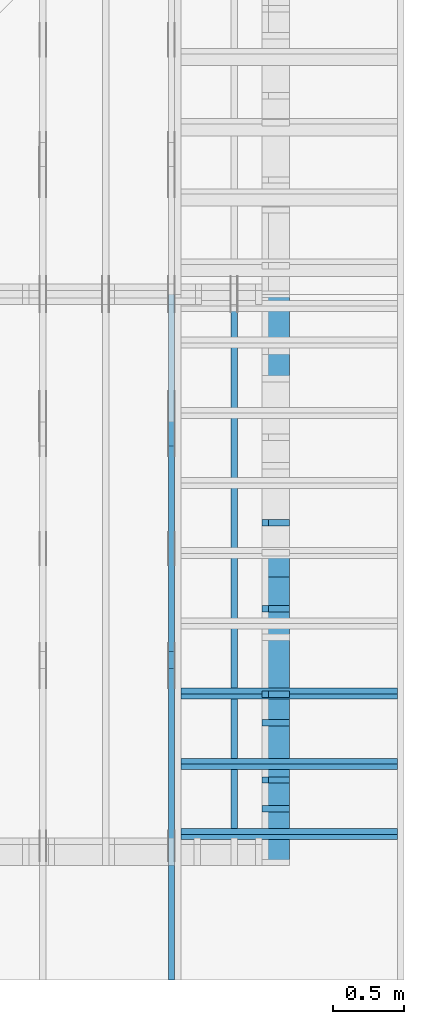
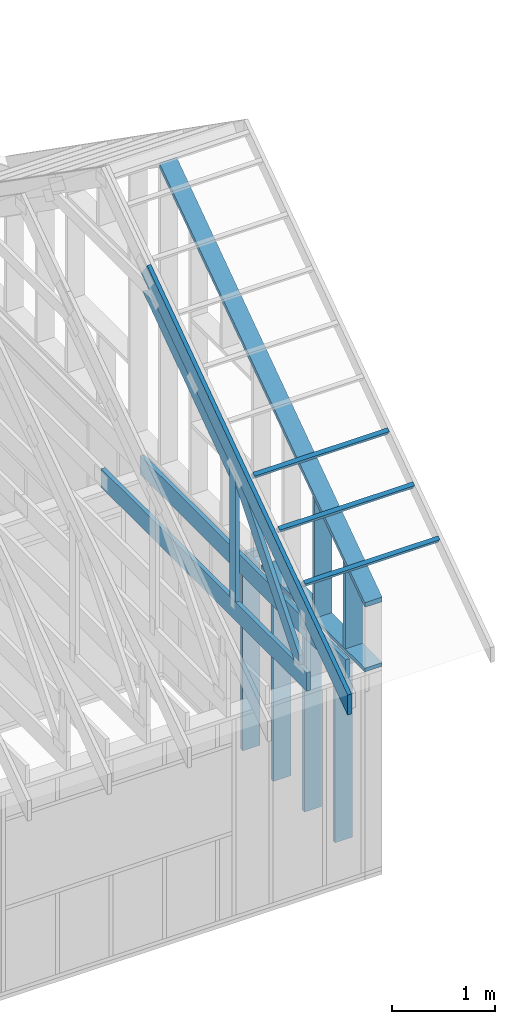
# One storey, part 22 of 70: 17 members, 5 elements without a shape of their own.
"""IFC2X3 building model written with IfcOpenShell, lengths in millimetres."""

from ifc_helpers import new_model, si_unit, frame, origin, origin_with_axes, origin_2d, place, context, project, spatial, faceted_brep, element, aggregate, save


model = new_model("IFC2X3")

# Units and contexts
model_context = context("Model", 3, precision=1e-05, world=origin())
plan_context = context("Plan", 2, precision=1e-05, world=origin_2d())
ifc_project = project(units=[si_unit("LENGTHUNIT", "METRE", prefix="MILLI"), si_unit("AREAUNIT", "SQUARE_METRE"), si_unit("VOLUMEUNIT", "CUBIC_METRE"), si_unit("SOLIDANGLEUNIT", "STERADIAN"), si_unit("PLANEANGLEUNIT", "RADIAN"), si_unit("MASSUNIT", "GRAM"), si_unit("TIMEUNIT", "SECOND"), si_unit("THERMODYNAMICTEMPERATUREUNIT", "DEGREE_CELSIUS"), si_unit("LUMINOUSINTENSITYUNIT", "LUMEN")], contexts=[model_context, plan_context])

# Site, building, storey
site_placement = place(None, origin_with_axes())
site = spatial("IfcSite", under=ifc_project, at=site_placement, CompositionType="ELEMENT")
building_placement = place(site_placement, origin_with_axes())
building = spatial("IfcBuilding", under=site, at=building_placement, Name="Layout 1", CompositionType="ELEMENT")
storey_placement = place(building_placement, origin_with_axes())
storey = spatial("IfcBuildingStorey", under=building, at=storey_placement, Name="Storey 1", CompositionType="ELEMENT", Elevation=0.0)

# Assembly, members
assembly_1_placement = place(storey_placement, frame((12000.0, 0.0, -2470.0), z_axis=(1.0, -6.123031769111886e-17, 6.123031769111886e-17), x_axis=(6.123031769111886e-17, 1.0, 0.0)))
assembly_1 = element("IfcElementAssembly", 1, at=assembly_1_placement, inside=storey, Name="VE5", AssemblyPlace="FACTORY", PredefinedType="NOTDEFINED")
member_1_placement = place(assembly_1_placement, frame((577.500000001819, 2425.0, -195.00000000000003), z_axis=(0.0, 0.0, 1.0), x_axis=(-1.836909530733566e-16, -1.0, 0.0)))
member_1 = element("IfcMember", 2, at=member_1_placement, Name="S11", context=model_context, shape_type="Brep", body=[
    faceted_brep([(0.0, 45.0, 45.00000000000003), (195.00000000186265, 45.0, 45.00000000000005), (195.00000000186265, 0.0, 45.00000000000005), (0.0, 0.0, 45.00000000000003), (195.00000000186265, -2.1311460639909362e-46, 2.842170943040401e-14), (195.00000000186265, -3.3742366240998114e-31, 45.00000000000003), (195.00000000186265, 45.0, 45.00000000000003), (195.00000000186265, 45.0, 2.842170943040401e-14), (2.7553642961003504e-15, -3.3742366240998114e-31, 45.00000000000003), (1.193991194976818e-14, -1.4621692037765842e-30, 195.00000000000003), (1.7450640541968876e-14, 45.0, 195.00000000000003), (8.266092888301048e-15, 45.0, 45.00000000000003), (2335.0, -4.2891837542628763e-13, 2.842170943040403e-14), (2335.0, -4.1697846347651946e-13, 195.00000000000003), (2.1932538056648764e-30, 1.193991194976818e-14, 195.00000000000003), (5.061354936149717e-31, 2.7553642961003504e-15, 45.00000000000003), (195.00000000186265, -3.306437155354634e-14, 45.00000000000003), (195.00000000186265, -3.5819735849646686e-14, 2.842170943040401e-14), (-1.6871183120499057e-31, 45.0, 45.00000000000003), (-7.310846018882921e-31, 44.999999999999986, 195.00000000000003), (2335.0, 44.999999999999844, 195.00000000000003), (2335.0, 44.99999999999986, 2.8421709430403992e-14), (195.00000000186265, 44.999999999999986, 2.842170943040401e-14), (195.00000000186265, 44.999999999999986, 45.00000000000003), (2335.0, 45.000000000000455, 0.0), (2335.0, 45.000000000000455, 195.00000000000003), (2335.0, 4.547473508864641e-13, 195.00000000000003), (2335.0, 4.547473508864641e-13, 0.0), (2335.0, 45.000000000000455, 195.00000000000003), (0.0, 45.000000000000455, 195.00000000000003), (0.0, 0.0, 195.00000000000003), (2335.0, 0.0, 195.00000000000003), (195.00000000186265, 45.0, 5.2301533330168465e-14), (2335.0, 45.0, 3.143672930479291e-13), (2335.0, 4.547473508864641e-13, 3.143672930479291e-13), (195.00000000186265, 4.547473508864641e-13, 5.2301533330168465e-14)], [[[0, 1, 2, 3]], [[4, 5, 6, 7]], [[8, 9, 10, 11]], [[12, 13, 14, 15, 16, 17]], [[18, 19, 20, 21, 22, 23]], [[24, 25, 26, 27]], [[28, 29, 30, 31]], [[32, 33, 34, 35]]]),
])
member_2_placement = place(assembly_1_placement, frame((1177.500000001819, 2425.0, -195.00000000000003), z_axis=(0.0, 0.0, 1.0), x_axis=(-1.836909530733566e-16, -1.0, 0.0)))
member_2 = element("IfcMember", 3, at=member_2_placement, Name="S11", context=model_context, shape_type="Brep", body=[
    faceted_brep([(0.0, 45.0, 45.00000000000003), (195.00000000186265, 45.0, 45.00000000000005), (195.00000000186265, 0.0, 45.00000000000005), (0.0, 0.0, 45.00000000000003), (195.00000000186265, -2.1311460639909362e-46, 2.842170943040401e-14), (195.00000000186265, -3.3742366240998114e-31, 45.00000000000003), (195.00000000186265, 45.0, 45.00000000000003), (195.00000000186265, 45.0, 2.842170943040401e-14), (2.7553642961003504e-15, -3.3742366240998114e-31, 45.00000000000003), (1.193991194976818e-14, -1.4621692037765842e-30, 195.00000000000003), (1.7450640541968876e-14, 45.0, 195.00000000000003), (8.266092888301048e-15, 45.0, 45.00000000000003), (2335.0, -4.2891837542628763e-13, 2.842170943040403e-14), (2335.0, -4.1697846347651946e-13, 195.00000000000003), (2.1932538056648764e-30, 1.193991194976818e-14, 195.00000000000003), (5.061354936149717e-31, 2.7553642961003504e-15, 45.00000000000003), (195.00000000186265, -3.306437155354634e-14, 45.00000000000003), (195.00000000186265, -3.5819735849646686e-14, 2.842170943040401e-14), (-1.6871183120499057e-31, 45.0, 45.00000000000003), (-7.310846018882921e-31, 44.999999999999986, 195.00000000000003), (2335.0, 44.999999999999844, 195.00000000000003), (2335.0, 44.99999999999986, 2.8421709430403998e-14), (195.00000000186265, 44.999999999999986, 2.842170943040401e-14), (195.00000000186265, 44.999999999999986, 45.00000000000003), (2335.0, 45.000000000000455, 0.0), (2335.0, 45.000000000000455, 195.00000000000003), (2335.0, 4.547473508864641e-13, 195.00000000000003), (2335.0, 4.547473508864641e-13, 0.0), (2335.0, 45.000000000000455, 195.00000000000003), (0.0, 45.000000000000455, 195.00000000000003), (0.0, 0.0, 195.00000000000003), (2335.0, 0.0, 195.00000000000003), (195.00000000186265, 45.0, 5.2301533330168465e-14), (2335.0, 45.0, 3.143672930479291e-13), (2335.0, 4.547473508864641e-13, 3.143672930479291e-13), (195.00000000186265, 4.547473508864641e-13, 5.2301533330168465e-14)], [[[0, 1, 2, 3]], [[4, 5, 6, 7]], [[8, 9, 10, 11]], [[12, 13, 14, 15, 16, 17]], [[18, 19, 20, 21, 22, 23]], [[24, 25, 26, 27]], [[28, 29, 30, 31]], [[32, 33, 34, 35]]]),
])
member_3_placement = place(assembly_1_placement, frame((1777.500000001819, 2425.0, -195.00000000000003), z_axis=(0.0, 0.0, 1.0), x_axis=(-1.836909530733566e-16, -1.0, 0.0)))
member_3 = element("IfcMember", 4, at=member_3_placement, Name="S11", context=model_context, shape_type="Brep", body=[
    faceted_brep([(0.0, 45.0, 45.00000000000003), (195.00000000186265, 45.0, 45.00000000000005), (195.00000000186265, 0.0, 45.00000000000005), (0.0, 0.0, 45.00000000000003), (195.00000000186265, -2.1311460639909362e-46, 2.842170943040401e-14), (195.00000000186265, -3.3742366240998114e-31, 45.00000000000003), (195.00000000186265, 45.0, 45.00000000000003), (195.00000000186265, 45.0, 2.842170943040401e-14), (2.7553642961003504e-15, -3.3742366240998114e-31, 45.00000000000003), (1.193991194976818e-14, -1.4621692037765842e-30, 195.00000000000003), (1.7450640541968876e-14, 45.0, 195.00000000000003), (8.266092888301048e-15, 45.0, 45.00000000000003), (2335.0, -4.2891837542628763e-13, 2.842170943040403e-14), (2335.0, -4.1697846347651946e-13, 195.00000000000003), (2.1932538056648764e-30, 1.193991194976818e-14, 195.00000000000003), (5.061354936149717e-31, 2.7553642961003504e-15, 45.00000000000003), (195.00000000186265, -3.306437155354634e-14, 45.00000000000003), (195.00000000186265, -3.5819735849646686e-14, 2.842170943040401e-14), (-1.6871183120499057e-31, 45.0, 45.00000000000003), (-7.310846018882921e-31, 44.999999999999986, 195.00000000000003), (2335.0, 44.999999999999844, 195.00000000000003), (2335.0, 44.99999999999986, 2.8421709430403998e-14), (195.00000000186265, 44.999999999999986, 2.842170943040401e-14), (195.00000000186265, 44.999999999999986, 45.00000000000003), (2335.0, 45.000000000000455, 0.0), (2335.0, 45.000000000000455, 195.00000000000003), (2335.0, 4.547473508864641e-13, 195.00000000000003), (2335.0, 4.547473508864641e-13, 0.0), (2335.0, 45.000000000000455, 195.00000000000003), (0.0, 45.000000000000455, 195.00000000000003), (0.0, 0.0, 195.00000000000003), (2335.0, 0.0, 195.00000000000003), (195.00000000186265, 45.0, 5.2301533330168465e-14), (2335.0, 45.0, 3.143672930479291e-13), (2335.0, 4.547473508864641e-13, 3.143672930479291e-13), (195.00000000186265, 4.547473508864641e-13, 5.2301533330168465e-14)], [[[0, 1, 2, 3]], [[4, 5, 6, 7]], [[8, 9, 10, 11]], [[12, 13, 14, 15, 16, 17]], [[18, 19, 20, 21, 22, 23]], [[24, 25, 26, 27]], [[28, 29, 30, 31]], [[32, 33, 34, 35]]]),
])
member_4_placement = place(assembly_1_placement, frame((2377.5000000018335, 2425.0, -195.0), z_axis=(0.0, 0.0, 1.0), x_axis=(-1.836909530733566e-16, -1.0, 0.0)))
member_4 = element("IfcMember", 5, at=member_4_placement, Name="S11", context=model_context, shape_type="Brep", body=[
    faceted_brep([(0.0, 44.99999999998545, 45.0), (195.00000000186265, 44.99999999998545, 45.00000000000002), (195.00000000186265, 0.0, 45.00000000000002), (0.0, 0.0, 45.0), (195.00000000186265, 0.0, 0.0), (195.00000000186265, -3.3742366240998092e-31, 45.0), (195.00000000186265, 44.99999999998545, 45.0), (195.00000000186265, 44.99999999998545, 0.0), (2.755364296100349e-15, -3.3742366240998092e-31, 45.0), (1.1939911949768178e-14, -1.462169203776584e-30, 195.0), (1.7450640541967096e-14, 44.99999999998545, 195.00000000000003), (8.266092888299264e-15, 44.99999999998545, 45.0), (2335.0, -4.2891837542628763e-13, 2.626280839091018e-29), (2335.0, -4.1697846347651946e-13, 195.0), (2.193253805664876e-30, 1.1939911949768178e-14, 195.0), (5.061354936149714e-31, 2.755364296100349e-15, 45.0), (195.00000000186265, -3.306437155354634e-14, 45.0), (195.00000000186265, -3.5819735849646686e-14, 2.193253805685826e-30), (-1.6871183120499046e-31, 44.99999999998545, 45.0), (-7.31084601888292e-31, 44.999999999985434, 195.0), (2335.0, 44.99999999998529, 195.0), (2335.0, 44.999999999985306, -8.67746995743113e-30), (195.00000000186265, 44.999999999985434, -7.888609052210118e-31), (195.00000000186265, 44.999999999985434, 45.0), (2335.0, 44.9999999999859, 2.842170943040401e-14), (2335.0, 44.9999999999859, 195.0), (2335.0, 4.547473508864641e-13, 195.0), (2335.0, 4.547473508864641e-13, 0.0), (2335.0, 44.9999999999859, 195.0), (0.0, 44.9999999999859, 195.0), (0.0, 0.0, 195.0), (2335.0, 0.0, 195.0), (195.00000000186265, 44.99999999998545, 2.3879823899764457e-14), (2335.0, 44.99999999998545, 2.859455836175251e-13), (2335.0, 4.547473508864641e-13, 2.859455836175251e-13), (195.00000000186265, 4.547473508864641e-13, 2.3879823899764457e-14)], [[[0, 1, 2, 3]], [[4, 5, 6, 7]], [[8, 9, 10, 11]], [[12, 13, 14, 15, 16, 17]], [[18, 19, 20, 21, 22, 23]], [[24, 25, 26, 27]], [[28, 29, 30, 31]], [[32, 33, 34, 35]]]),
])
aggregate(assembly_1, [member_1, member_2, member_3, member_4])

# Assembly, member
assembly_2_placement = place(storey_placement, frame((11588.750000000146, 8000.0, 1.3776821480501744e-15), z_axis=(-1.0, 1.836909530733566e-16, 6.123031769111886e-17), x_axis=(-1.836909530733566e-16, -1.0, 0.0)))
assembly_2 = element("IfcElementAssembly", 6, at=assembly_2_placement, inside=storey, Name="MB1", AssemblyPlace="FACTORY", PredefinedType="TRUSS")
member_5_placement = place(assembly_2_placement, frame((8000.000000000001, 220.0, -45.0), z_axis=(0.0, 0.0, 1.0), x_axis=(-1.0, 1.2246063538223773e-16, 0.0)))
member_5 = element("IfcMember", 7, at=member_5_placement, Name="B3", context=model_context, shape_type="Brep", body=[
    faceted_brep([(4000.0000000000005, 220.0000000000005, 45.0), (0.0, 220.0000000000005, 45.0), (0.0, 0.0, 45.0), (4000.0000000000005, 0.0, 45.0), (0.0, 220.0000000000005, 0.0), (4000.0000000000005, 220.0000000000005, 4.89842541528951e-13), (4000.0000000000005, 0.0, 4.89842541528951e-13), (0.0, 0.0, 0.0), (0.0, 0.0, 0.0), (2.755364296100349e-15, -3.3742366240998092e-31, 45.0), (2.969670408019265e-14, 220.0, 45.0), (2.69413397840923e-14, 220.0, -1.6496267940043512e-30), (4000.0000000000005, -7.347638122934265e-13, 7.631468701413364e-29), (4000.0000000000005, -7.320084479973261e-13, 45.0), (5.061354936149714e-31, 2.755364296100349e-15, 45.0), (0.0, 0.0, 0.0), (4000.0000000000005, 220.0000000000005, 0.0), (4000.0000000000005, 220.0000000000005, 45.0), (4000.0000000000005, 5.115907697472721e-13, 45.0), (4000.0000000000005, 5.115907697472721e-13, 0.0), (0.0, 220.0, 0.0), (0.0, 220.0, 45.0), (4000.0000000000005, 220.00000000000065, 45.0), (4000.0000000000005, 220.00000000000065, 7.888609052210118e-30)], [[[0, 1, 2, 3]], [[4, 5, 6, 7]], [[8, 9, 10, 11]], [[12, 13, 14, 15]], [[16, 17, 18, 19]], [[20, 21, 22, 23]]]),
])
aggregate(assembly_2, [member_5])

# Assembly, members
assembly_3_placement = place(storey_placement, frame((11150.0, 8000.0, -9.081170196248781e-13), z_axis=(-1.0, 1.836909530733566e-16, 6.123031769111886e-17), x_axis=(-1.836909530733566e-16, -1.0, 0.0)))
assembly_3 = element("IfcElementAssembly", 8, at=assembly_3_placement, inside=storey, Name="T3", AssemblyPlace="FACTORY", PredefinedType="TRUSS")
member_6_placement = place(assembly_3_placement, frame((4782.309641269037, 3015.0000000009313, -45.00000000000001), z_axis=(0.0, 0.0, 1.0), x_axis=(0.8191520442889916, -0.5735764363510465, 0.0)))
member_6 = element("IfcMember", 9, at=member_6_placement, Name="T8", context=model_context, shape_type="Brep", body=[
    faceted_brep([(4768.153825500145, 194.99999999946158, 45.0), (1.6370904631912708e-10, 194.99999999946158, 45.0), (0.0, 0.0, 45.0), (4904.694295450095, 0.0, 45.0), (1.6370904631912708e-10, 194.99999999946158, 2.004791383006049e-26), (4768.153825500145, 194.99999999946158, 5.839111470709952e-13), (4904.694295450095, 0.0, 6.006319797764554e-13), (0.0, 0.0, 0.0), (2.5849394142282115e-26, -2.1699301500556333e-38, -1.582766615454881e-42), (2.7553642961261982e-15, -2.3129934990511945e-27, 45.0), (1.6369571347777126e-10, 194.99999999920783, 45.0), (1.6369295811347516e-10, 194.99999999920783, 9.850859431479521e-31), (4904.694295450095, 8.093603669211209e-10, 5.505686690999094e-30), (4904.694295450095, 8.09363122285417e-10, 45.0), (-4.546833142611764e-28, 2.755364296100349e-15, 45.0), (0.0, 0.0, 0.0), (4768.153825500146, 194.99999999946203, 5.048709793414476e-29), (4768.153825500146, 194.99999999946203, 45.0), (4904.6942954500955, 8.094502845779061e-10, 45.0), (4904.6942954500955, 8.094502845779061e-10, 5.048709793414476e-29), (1.6370904631912708e-10, 194.99999999920783, 0.0), (1.6370904631912708e-10, 194.99999999920783, 45.0), (4768.153825500145, 194.99999999946164, 45.0), (4768.153825500145, 194.99999999946164, 3.1554436208840472e-30)], [[[0, 1, 2, 3]], [[4, 5, 6, 7]], [[8, 9, 10, 11]], [[12, 13, 14, 15]], [[16, 17, 18, 19]], [[20, 21, 22, 23]]]),
])
member_7_placement = place(assembly_3_placement, frame((7999.999999999999, 220.0, -45.0), z_axis=(0.0, 0.0, 1.0), x_axis=(-1.0, 1.2246063538223773e-16, 0.0)))
member_7 = element("IfcMember", 10, at=member_7_placement, Name="B3", context=model_context, shape_type="Brep", body=[
    faceted_brep([(3999.9999999999995, 220.00000000000048, 45.0), (0.0, 220.00000000000048, 45.0), (0.0, 0.0, 45.0), (3999.9999999999995, 0.0, 45.0), (0.0, 220.00000000000048, 0.0), (3999.9999999999995, 220.00000000000048, 4.898425415289508e-13), (3999.9999999999995, 0.0, 4.898425415289508e-13), (0.0, 0.0, 0.0), (0.0, 0.0, 0.0), (2.755364296100349e-15, -3.3742366240998092e-31, 45.0), (2.969670408019265e-14, 220.0, 45.0), (2.69413397840923e-14, 220.0, -1.6496267940043512e-30), (3999.9999999999995, -7.347638122934263e-13, 7.457441671638533e-29), (3999.9999999999995, -7.320084479973259e-13, 45.0), (5.061354936149714e-31, 2.755364296100349e-15, 45.0), (0.0, 0.0, 0.0), (3999.9999999999995, 220.00000000000048, 0.0), (3999.9999999999995, 220.00000000000048, 45.0), (3999.9999999999995, 4.831690603168681e-13, 45.0), (3999.9999999999995, 4.831690603168681e-13, 0.0), (0.0, 220.0, 0.0), (0.0, 220.0, 45.0), (3999.9999999999995, 220.00000000000065, 45.0), (3999.9999999999995, 220.00000000000065, 9.466330862652142e-30)], [[[0, 1, 2, 3]], [[4, 5, 6, 7]], [[8, 9, 10, 11]], [[12, 13, 14, 15]], [[16, 17, 18, 19]], [[20, 21, 22, 23]]]),
])
member_8_placement = place(assembly_3_placement, frame((6583.168583270521, 1754.024964554012, -44.99999999999999), z_axis=(0.0, 0.0, 1.0), x_axis=(-0.8191520442890866, 0.5735764363509106, 0.0)))
member_8 = element("IfcMember", 11, at=member_8_placement, Name="SC5", context=model_context, shape_type="Brep", body=[
    faceted_brep([(2065.552220741256, 145.00000000323507, 45.0), (0.0, 145.00000000323507, 45.0), (101.53009304067928, 0.0, 45.0), (1858.4707597638994, 0.0, 45.0), (0.0, 145.00000000323507, 0.0), (2065.552220741256, 145.00000000323507, 2.5294883736716636e-13), (1858.4707597638994, 0.0, 2.275895100799972e-13), (101.53009304067928, 0.0, 1.2433439704179296e-14), (101.53009304067926, -1.4210854715202004e-14, 1.2188192559213497e-30), (101.53009304067926, -1.4210854715202004e-14, 45.0), (2.842170943040401e-14, 145.0000000003174, 45.0), (2.842170943040401e-14, 145.0000000003174, -8.457017451291223e-31), (1858.4707597638994, 3.6386987741452655e-09, 1.1604838111769461e-29), (1858.4707597638994, 3.6387015295095616e-09, 45.0), (101.53009304067928, -7.598718304623376e-15, 45.0), (101.53009304067928, -1.0354082600723725e-14, 6.339837670416306e-31), (2065.552220741256, 145.00000000323575, -3.7865323450608567e-29), (2065.552220741256, 145.00000000323575, 45.0), (1858.4707597638994, 3.639456735982094e-09, 45.0), (1858.4707597638994, 3.639456735982094e-09, -3.7865323450608567e-29), (0.0, 145.0000000003174, 0.0), (0.0, 145.0000000003174, 45.0), (2065.552220741256, 145.00000000323564, 45.0), (2065.552220741256, 145.00000000323564, 3.6287601640166543e-29)], [[[0, 1, 2, 3]], [[4, 5, 6, 7]], [[8, 9, 10, 11]], [[12, 13, 14, 15]], [[16, 17, 18, 19]], [[20, 21, 22, 23]]]),
])
member_9_placement = place(assembly_3_placement, frame((6619.999999999389, 220.0, -45.0), z_axis=(0.0, 0.0, 1.0), x_axis=(6.123031769111886e-17, 1.0, 0.0)))
member_9 = element("IfcMember", 12, at=member_9_placement, Name="R1", context=model_context, shape_type="Brep", body=[
    faceted_brep([(1592.2602625068248, 120.0, 45.0), (0.0, 120.0, 45.0), (0.0, 1.4551915228366852e-11, 45.0), (1508.235357921585, 1.4551915228366852e-11, 45.0), (0.0, 120.0, 0.0), (1592.2602625068248, 120.0, 1.949892034404744e-13), (1508.235357921585, 1.4551915228366852e-11, 1.8469946023703405e-13), (0.0, 1.4551915228366852e-11, 0.0), (1.7820367848942657e-27, 1.4551915228366852e-11, -1.0911467847633593e-43), (2.755364296102131e-15, 1.4551915228366852e-11, 45.0), (1.7450640541968876e-14, 120.0, 45.0), (1.4695276245868527e-14, 120.0, -8.997964330932825e-31), (1508.235357921585, -4.605370260698061e-13, 2.81988284147774e-29), (1508.235357921585, -4.577816617737058e-13, 45.0), (2.7425941661909085e-29, 1.4554670592662952e-11, 45.0), (0.0, 1.4551915228366852e-11, 0.0), (1592.260262506825, 120.00000000000011, 1.262177448353619e-29), (1592.260262506825, 120.00000000000011, 45.0), (1508.2353579215853, 0.0, 45.0), (1508.2353579215853, 0.0, 1.262177448353619e-29), (0.0, 120.0, 0.0), (-1.6871183120499046e-31, 120.0, 45.0), (1592.2602625068248, 119.9999999999999, 45.0), (1592.2602625068248, 119.9999999999999, -6.310887241768095e-30)], [[[0, 1, 2, 3]], [[4, 5, 6, 7]], [[8, 9, 10, 11]], [[12, 13, 14, 15]], [[16, 17, 18, 19]], [[20, 21, 22, 23]]]),
])
member_10_placement = place(assembly_3_placement, frame((6563.906131861293, 1682.303582892756, -45.0), z_axis=(0.0, 0.0, 1.0), x_axis=(0.6335417245359889, -0.7737085260432156, 0.0)))
member_10 = element("IfcMember", 13, at=member_10_placement, Name="W6", context=model_context, shape_type="Brep", body=[
    faceted_brep([(1860.8184531590368, 145.00000000000182, 45.0), (258.1329393113165, 145.00000000000182, 45.0), (0.0, 72.4999999999518, 45.0), (88.54013234752438, 0.0, 45.0), (1889.9928508879848, 0.0, 45.0), (1949.3585855061046, 72.4999999999518, 45.0), (258.1329393113165, 145.00000000000182, 3.161112376114843e-14), (1860.8184531590368, 145.00000000000182, 2.2787701010484843e-13), (1949.3585855061046, 72.4999999999518, 2.3871969096889775e-13), (1889.9928508879848, 0.0, 2.314497253876295e-13), (88.54013234752438, 0.0, 1.0842680864105255e-14), (0.0, 72.4999999999518, 0.0), (3.552713678800501e-15, 72.49999999995178, -7.284513455813184e-31), (3.552713678800501e-15, 72.49999999995178, 45.0), (258.13293931131653, 144.9999999999991, 45.0), (258.13293931131653, 144.9999999999991, 8.866211437223917e-31), (88.54013234752439, 0.0, 8.758115402030107e-47), (88.54013234752439, 0.0, 45.0), (0.0, 72.49999999995181, 45.0), (0.0, 72.4999999999518, 8.758115402030107e-47), (1889.9928508879848, 1.2420742274003826e-12, 3.532469951621517e-29), (1889.9928508879848, 1.244829591696483e-12, 45.0), (88.54013234752438, -2.4271270235991317e-14, 45.0), (88.54013234752438, -2.7026634532091666e-14, 1.654849418521736e-30), (1949.3585855061053, 72.49999999999955, 6.310887241768094e-29), (1949.3585855061053, 72.49999999999955, 45.0), (1889.9928508879855, 1.3642420526593924e-12, 45.0), (1889.9928508879855, 1.3642420526593924e-12, 6.310887241768094e-29), (1860.8184531590368, 145.00000000000182, 0.0), (1860.8184531590368, 145.00000000000182, 45.0), (1949.3585855061046, 72.5, 45.0), (1949.3585855061046, 72.5, 0.0), (258.1329393113165, 144.99999999999912, 0.0), (258.1329393113165, 144.9999999999991, 45.0), (1860.8184531590368, 145.00000000000185, 45.0), (1860.8184531590368, 145.00000000000185, 1.5777218104420236e-30)], [[[0, 1, 2, 3, 4, 5]], [[6, 7, 8, 9, 10, 11]], [[12, 13, 14, 15]], [[16, 17, 18, 19]], [[20, 21, 22, 23]], [[24, 25, 26, 27]], [[28, 29, 30, 31]], [[32, 33, 34, 35]]]),
])
aggregate(assembly_3, [member_6, member_7, member_8, member_9, member_10])

assembly_4_placement = place(storey_placement, frame((11805.0, 8000.000000000002, 1.1939911949768178e-14), z_axis=(-1.0, 1.836909530733566e-16, 6.123031769111886e-17), x_axis=(-1.836909530733566e-16, -1.0, 0.0)))
assembly_4 = element("IfcElementAssembly", 14, at=assembly_4_placement, inside=storey, Name="VE9", AssemblyPlace="FACTORY", PredefinedType="NOTDEFINED")
member_11_placement = place(assembly_4_placement, frame((3974.1890603636384, 3586.955995475468, -195.00000000000003), z_axis=(0.0, 0.0, 1.0), x_axis=(0.8191520442889916, -0.5735764363510465, 0.0)))
member_11 = element("IfcMember", 15, at=member_11_placement, Name="P6", context=model_context, shape_type="Brep", body=[
    faceted_brep([(4883.098355046161, 45.00000000051023, 195.0), (0.0, 45.00000000051023, 195.0), (31.509339218725927, 2.000888343900442e-09, 195.0), (4914.607694265955, 2.000888343900442e-09, 195.0), (0.0, 45.00000000051023, 0.0), (4883.098355046161, 45.00000000051023, 5.979873271929127e-13), (4914.607694265955, 2.000888343900442e-09, 6.018459808942432e-13), (31.509339218725927, 2.000888343900442e-09, 3.858653701199639e-15), (31.50933921872593, 2.0008865675436027e-09, -8.583167491523293e-32), (31.50933921872594, 2.0008936729709603e-09, 195.0), (1.0658141036401503e-14, 45.00000000098499, 195.0), (0.0, 45.00000000098498, -2.2717864096368696e-31), (4914.607694265955, 6.094206430249401e-13, -3.7315019579951877e-29), (4914.607694265955, 6.213605549747082e-13, 195.0), (31.509339218725927, 2.0009041910300097e-09, 195.0), (31.509339218725927, 2.00089225111806e-09, -2.3924017602207903e-31), (4883.098355046161, 45.000000000511136, 5.048709793414476e-29), (4883.098355046161, 45.000000000511136, 195.0), (4914.607694265956, 9.094947017729282e-13, 195.0), (4914.607694265956, 9.094947017729282e-13, 5.048709793414476e-29), (0.0, 45.00000000098498, 0.0), (-8.077935669463161e-28, 45.00000000098497, 195.0), (4883.098355046161, 45.000000000509765, 195.0), (4883.098355046161, 45.00000000050978, -2.7610131682735413e-29)], [[[0, 1, 2, 3]], [[4, 5, 6, 7]], [[8, 9, 10, 11]], [[12, 13, 14, 15]], [[16, 17, 18, 19]], [[20, 21, 22, 23]]]),
])
member_12_placement = place(assembly_4_placement, frame((8000.000000000002, 45.0, -195.0), z_axis=(0.0, 0.0, 1.0), x_axis=(-1.0, 1.2246063538223773e-16, 0.0)))
member_12 = element("IfcMember", 16, at=member_12_placement, Name="P11", context=model_context, shape_type="Brep", body=[
    faceted_brep([(2020.000000000001, 45.00000000000025, 195.0), (0.0, 45.00000000000025, 195.0), (0.0, 0.0, 195.0), (2020.000000000001, 0.0, 195.0), (0.0, 45.00000000000025, 0.0), (2020.000000000001, 45.00000000000025, 2.473704834721203e-13), (2020.000000000001, 0.0, 2.473704834721203e-13), (0.0, 0.0, 0.0), (0.0, 0.0, 0.0), (1.1939911949768178e-14, -1.462169203776584e-30, 195.0), (1.7450640541968876e-14, 45.0, 195.0), (5.510728592200698e-15, 45.0, -3.3742366240998092e-31), (2020.000000000001, -3.7105572520818046e-13, 3.7947225040903074e-29), (2020.000000000001, -3.591158132584123e-13, 195.0), (2.193253805664876e-30, 1.1939911949768178e-14, 195.0), (0.0, 0.0, 0.0), (2020.000000000001, 45.00000000000025, 0.0), (2020.000000000001, 45.00000000000025, 195.0), (2020.000000000001, 2.4868995751603507e-13, 195.0), (2020.000000000001, 2.4868995751603507e-13, 0.0), (0.0, 45.0, 0.0), (1.5777218104420236e-30, 44.999999999999986, 195.0), (2020.000000000001, 45.00000000000031, 195.0), (2020.000000000001, 45.00000000000033, 4.338734978715565e-30)], [[[0, 1, 2, 3]], [[4, 5, 6, 7]], [[8, 9, 10, 11]], [[12, 13, 14, 15]], [[16, 17, 18, 19]], [[20, 21, 22, 23]]]),
])
member_13_placement = place(assembly_4_placement, frame((6977.500000001819, 1484.0150359537365, -195.0), z_axis=(0.0, 0.0, 1.0), x_axis=(-1.836909530733566e-16, -1.0, 0.0)))
member_13 = element("IfcMember", 17, at=member_13_placement, Name="S20", context=model_context, shape_type="Brep", body=[
    faceted_brep([(1439.0150359537365, 45.0, 195.0), (31.50933921946853, 45.0, 195.0), (0.0, 1.4551915228366852e-11, 195.0), (1439.0150359537365, 1.4551915228366852e-11, 195.0), (31.50933921946853, 45.0, 3.858653701290579e-15), (1439.0150359537365, 45.0, 1.7622269562748824e-13), (1439.0150359537365, 1.4551915228366852e-11, 1.7622269562748824e-13), (0.0, 1.4551915228366852e-11, 0.0), (-4.746314461759238e-15, 1.4555238633531696e-11, 3.547794873757377e-31), (5.0342888205204204e-15, 1.4548390181385197e-11, 195.0), (31.509339219468515, 45.00000000001456, 195.0), (31.509339219468504, 45.000000000014566, 1.9591359440661738e-30), (1439.0150359537365, 2.2845807878642543e-13, -1.3988560743195544e-29), (1439.0150359537365, 2.403979907361936e-13, 195.0), (1.1884574720160603e-28, 1.456385514031662e-11, 195.0), (0.0, 1.4551915228366852e-11, 0.0), (1439.0150359537365, 45.0, 0.0), (1439.0150359537365, 45.0, 195.0), (1439.0150359537365, 0.0, 195.0), (1439.0150359537365, 0.0, 0.0), (31.50933921946853, 45.00000000001455, 3.944304526105059e-31), (31.50933921946853, 45.000000000014545, 195.0), (1439.0150359537365, 45.00000000000008, 195.0), (1439.0150359537365, 45.00000000000009, 5.9164567891575885e-30)], [[[0, 1, 2, 3]], [[4, 5, 6, 7]], [[8, 9, 10, 11]], [[12, 13, 14, 15]], [[16, 17, 18, 19]], [[20, 21, 22, 23]]]),
])
member_14_placement = place(assembly_4_placement, frame((7577.500000001819, 1063.890513027538, -195.0), z_axis=(0.0, 0.0, 1.0), x_axis=(-1.836909530733566e-16, -1.0, 0.0)))
member_14 = element("IfcMember", 18, at=member_14_placement, Name="S30", context=model_context, shape_type="Brep", body=[
    faceted_brep([(1018.890513027538, 45.0, 195.0), (31.50933921946853, 45.0, 195.0), (0.0, 2.9103830456733704e-11, 195.0), (1018.890513027538, 2.9103830456733704e-11, 195.0), (31.50933921946853, 45.0, 3.858653701290579e-15), (1018.890513027538, 45.0, 1.2477397961028645e-13), (1018.890513027538, 2.9103830456733704e-11, 1.2477397961028645e-13), (0.0, 2.9103830456733704e-11, 0.0), (-3.6722035779941564e-15, 2.910640176136086e-11, 2.744914003143988e-31), (6.108399704285502e-15, 2.9099553309214365e-11, 195.0), (31.50933921946852, 45.00000000002912, 195.0), (31.509339219468508, 45.000000000029125, 1.9613507635022927e-30), (1018.890513027538, -4.194061534567667e-14, 2.56803720177698e-30), (1018.890513027538, -3.000070339590849e-14, 195.0), (3.415459618665846e-28, 2.911577036868347e-11, 195.0), (0.0, 2.9103830456733704e-11, 0.0), (1018.890513027538, 45.0, 0.0), (1018.890513027538, 45.0, 195.0), (1018.890513027538, 0.0, 195.0), (1018.890513027538, 0.0, 0.0), (31.50933921946853, 45.00000000002911, 0.0), (31.50933921946853, 45.0000000000291, 195.0), (1018.890513027538, 45.0000000000001, 195.0), (1018.890513027538, 45.00000000000011, 6.310887241768095e-30)], [[[0, 1, 2, 3]], [[4, 5, 6, 7]], [[8, 9, 10, 11]], [[12, 13, 14, 15]], [[16, 17, 18, 19]], [[20, 21, 22, 23]]]),
])
aggregate(assembly_4, [member_11, member_12, member_13, member_14])

assembly_5_placement = place(storey_placement, frame((12800.0, -800.0, 439.83396943223215), z_axis=(-2.4046889635939937e-17, -0.573576436351046, 0.8191520442889918), x_axis=(1.5036672491230068e-17, 0.8191520442889918, 0.573576436351046)))
assembly_5 = element("IfcElementAssembly", 19, at=assembly_5_placement, inside=storey, Name="gs2", AssemblyPlace="FACTORY", PredefinedType="TRUSS")
member_15_placement = place(assembly_5_placement, frame((1244.9999999994034, 44.99999999999999, -70.0), z_axis=(0.0, 0.0, 1.0), x_axis=(6.123031769111886e-17, 1.0, 0.0)))
member_15 = element("IfcMember", 20, at=member_15_placement, Name="W5", context=model_context, shape_type="Brep", body=[
    faceted_brep([(1514.9999999999982, 45.0, 70.0), (0.0, 45.0, 70.0), (7.105427357601002e-15, 2.9103830456733704e-11, 70.0), (1514.9999999999982, 2.9103830456733704e-11, 70.0), (0.0, 45.0, 0.0), (1514.9999999999982, 45.0, 1.8552786260408993e-13), (1514.9999999999982, 2.9103830456733704e-11, 1.8552786260408993e-13), (7.105427357601002e-15, 2.9103830456733704e-11, 8.701351488741532e-31), (7.105427357609162e-15, 2.9103830456733704e-11, -4.996504836858176e-43), (1.1391549595987482e-14, 2.9103830456733704e-11, 70.0), (1.69022781881864e-14, 45.00000000001455, 70.0), (1.2616155949808077e-14, 45.00000000001455, -7.72491236847448e-31), (1514.9999999999982, -7.774480657775668e-13, 4.7603392055906514e-29), (1514.9999999999982, -7.731619435391885e-13, 70.0), (7.105427357601087e-15, 2.910811657897208e-11, 70.0), (7.105427357601002e-15, 2.9103830456733704e-11, 0.0), (1514.9999999999982, 45.0, 0.0), (1514.9999999999982, 45.0, 70.0), (1514.9999999999982, 0.0, 70.0), (1514.9999999999982, 0.0, 0.0), (0.0, 45.00000000001455, 0.0), (-5.048709793414476e-29, 45.000000000014545, 70.0), (1514.9999999999982, 44.99999999999999, 70.0), (1514.9999999999982, 44.99999999999999, -3.944304526105059e-31)], [[[0, 1, 2, 3]], [[4, 5, 6, 7]], [[8, 9, 10, 11]], [[12, 13, 14, 15]], [[16, 17, 18, 19]], [[20, 21, 22, 23]]]),
])
member_16_placement = place(assembly_5_placement, frame((1844.9999999994034, 45.0, -70.0), z_axis=(0.0, 0.0, 1.0), x_axis=(6.123031769111886e-17, 1.0, 0.0)))
member_16 = element("IfcMember", 21, at=member_16_placement, Name="W5", context=model_context, shape_type="Brep", body=[
    faceted_brep([(1514.9999999999982, 45.0, 70.0), (0.0, 45.0, 70.0), (0.0, 1.4551915228366852e-11, 70.0), (1514.9999999999982, 1.4551915228366852e-11, 70.0), (0.0, 45.0, 0.0), (1514.9999999999982, 45.0, 1.8552786260408993e-13), (1514.9999999999982, 1.4551915228366852e-11, 1.8552786260408993e-13), (0.0, 1.4551915228366852e-11, 0.0), (1.7820367848942657e-27, 1.4551915228366852e-11, -1.0911467847633593e-43), (4.2861222383801024e-15, 1.4551915228366852e-11, 70.0), (9.796850830580801e-15, 45.00000000001455, 70.0), (5.51072859220248e-15, 45.00000000001455, -3.3742366241009005e-31), (1514.9999999999982, -5.27869929841851e-13, 3.2321643503805275e-29), (1514.9999999999982, -5.235838076034727e-13, 70.0), (4.2662575918525243e-29, 1.455620135060523e-11, 70.0), (0.0, 1.4551915228366852e-11, 0.0), (1514.9999999999982, 45.0, 0.0), (1514.9999999999982, 45.0, 70.0), (1514.9999999999982, 0.0, 70.0), (1514.9999999999982, 0.0, 0.0), (0.0, 45.00000000001455, 0.0), (-5.048709793414476e-29, 45.000000000014545, 70.0), (1514.9999999999982, 44.99999999999999, 70.0), (1514.9999999999982, 44.99999999999999, -3.944304526105059e-31)], [[[0, 1, 2, 3]], [[4, 5, 6, 7]], [[8, 9, 10, 11]], [[12, 13, 14, 15]], [[16, 17, 18, 19]], [[20, 21, 22, 23]]]),
])
member_17_placement = place(assembly_5_placement, frame((2444.9999999994034, 45.0, -70.0), z_axis=(0.0, 0.0, 1.0), x_axis=(6.123031769111886e-17, 1.0, 0.0)))
member_17 = element("IfcMember", 22, at=member_17_placement, Name="W5", context=model_context, shape_type="Brep", body=[
    faceted_brep([(1514.9999999999982, 45.0, 70.0), (0.0, 45.0, 70.0), (0.0, 1.4551915228366852e-11, 70.0), (1514.9999999999982, 1.4551915228366852e-11, 70.0), (0.0, 45.0, 0.0), (1514.9999999999982, 45.0, 1.8552786260408993e-13), (1514.9999999999982, 1.4551915228366852e-11, 1.8552786260408993e-13), (0.0, 1.4551915228366852e-11, 0.0), (1.7820367848942657e-27, 1.4551915228366852e-11, -1.0911467847633593e-43), (4.2861222383801024e-15, 1.4551915228366852e-11, 70.0), (9.796850830582582e-15, 45.000000000029104, 70.0), (5.510728592204262e-15, 45.000000000029104, -3.3742366241019913e-31), (1514.9999999999982, -5.27869929841851e-13, 3.2321643503805275e-29), (1514.9999999999982, -5.235838076034727e-13, 70.0), (4.2662575918525243e-29, 1.455620135060523e-11, 70.0), (0.0, 1.4551915228366852e-11, 0.0), (1514.9999999999982, 45.0, 0.0), (1514.9999999999982, 45.0, 70.0), (1514.9999999999982, 0.0, 70.0), (1514.9999999999982, 0.0, 0.0), (0.0, 45.000000000029104, 0.0), (-1.0097419586828951e-28, 45.0000000000291, 70.0), (1514.9999999999982, 45.00000000000008, 70.0), (1514.9999999999982, 45.00000000000008, 5.127595883936577e-30)], [[[0, 1, 2, 3]], [[4, 5, 6, 7]], [[8, 9, 10, 11]], [[12, 13, 14, 15]], [[16, 17, 18, 19]], [[20, 21, 22, 23]]]),
])
aggregate(assembly_5, [member_15, member_16, member_17])

save(model, "model.ifc")
